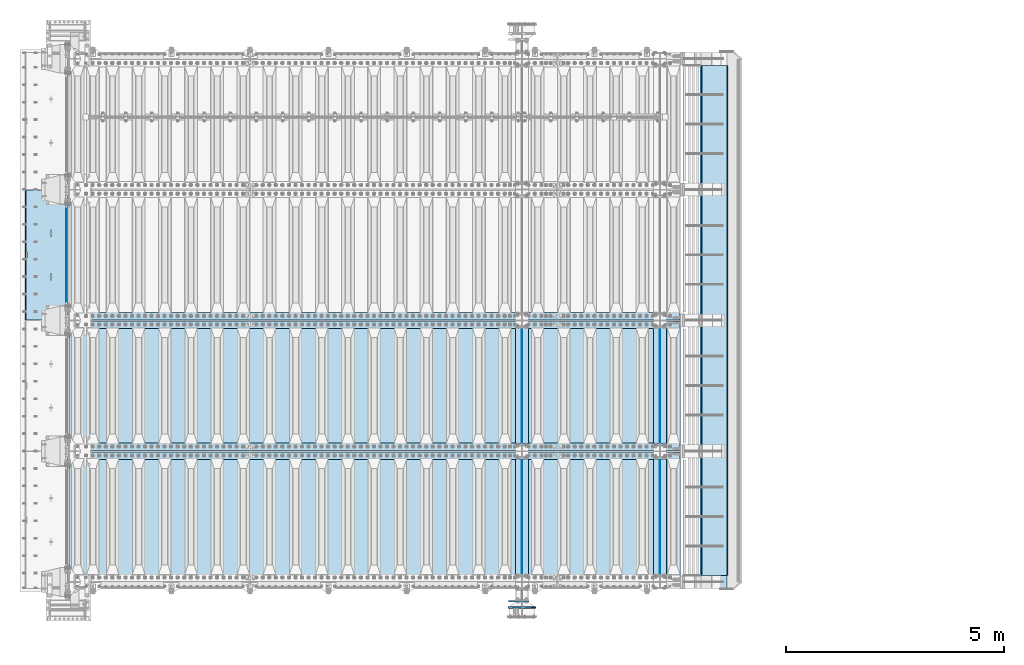
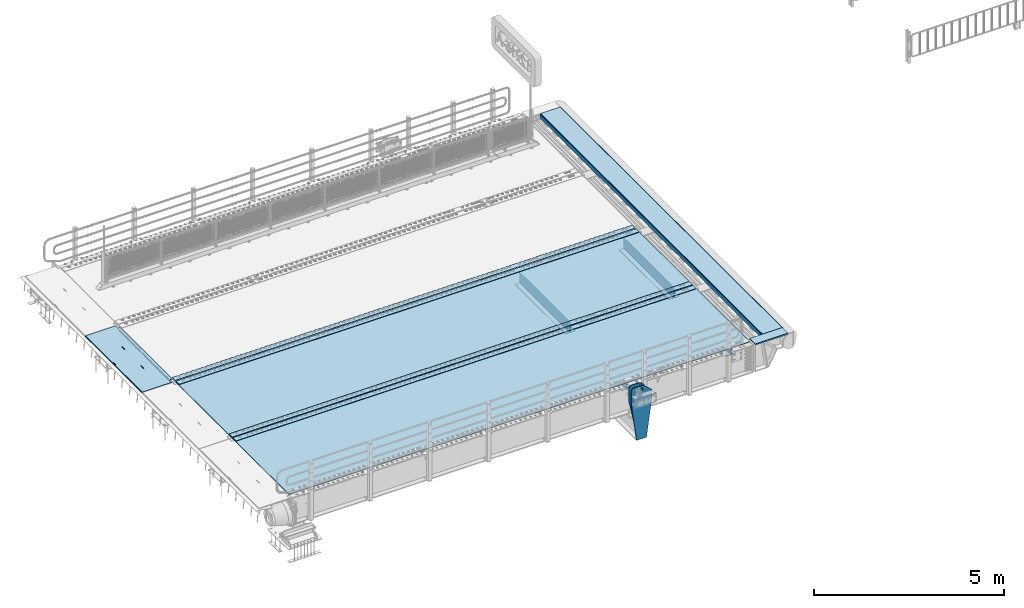
# One storey, part 187 of 240: 21 plates.
"""IFC2X3 building model written with IfcOpenShell, lengths in millimetres."""

from ifc_helpers import new_model, si_unit, frame, origin_with_axes, place, context, subcontext, project, spatial, faceted_brep, material, type_object, element, save


model = new_model("IFC2X3")

# Units and contexts
model_context = context("Model", 3, precision=1e-05, world=origin_with_axes())
body_context = subcontext(model_context, "Body", "Model", "MODEL_VIEW")
ifc_project = project(units=[si_unit("LENGTHUNIT", "METRE", prefix="MILLI"), si_unit("AREAUNIT", "SQUARE_METRE"), si_unit("VOLUMEUNIT", "CUBIC_METRE"), si_unit("MASSUNIT", "GRAM", prefix="KILO"), si_unit("TIMEUNIT", "SECOND"), si_unit("PLANEANGLEUNIT", "RADIAN"), si_unit("SOLIDANGLEUNIT", "STERADIAN"), si_unit("THERMODYNAMICTEMPERATUREUNIT", "DEGREE_CELSIUS"), si_unit("LUMINOUSINTENSITYUNIT", "LUMEN")], contexts=[model_context])

# Site, building, storey
site_placement = place(None, origin_with_axes())
site = spatial("IfcSite", under=ifc_project, at=site_placement, CompositionType="ELEMENT")
building_placement = place(site_placement, origin_with_axes())
building = spatial("IfcBuilding", under=site, at=building_placement, Name="Standard", CompositionType="ELEMENT")
storey_placement = place(building_placement, origin_with_axes())
storey = spatial("IfcBuildingStorey", under=building, at=storey_placement, Name="Undefined", CompositionType="ELEMENT", Elevation=0.0)

# Plates
ifc_material_1 = material(Name="STEEL/S355N")
plate_type_1 = type_object("IfcPlateType", PredefinedType="NOTDEFINED")
plate_1_placement = place(storey_placement, frame((42392.5, 32845.0000994083, -36.0014545213866), z_axis=(0.0, -0.999999999987744, -4.95099999993769e-06), x_axis=(0.0, 4.9510000093107e-06, -0.999999999987744)))
element("IfcPlate", 1, at=plate_1_placement, inside=storey, type_object=plate_type_1, material=ifc_material_1, context=body_context, shape_type="Brep", body=[
    faceted_brep([(7.105427357601e-15, -7.5, 0.0), (-1.24849464100407e-10, -7.5, 70.0), (-1.24849464100407e-10, 7.5, 70.0), (7.105427357601e-15, 7.5, 0.0), (-14.9899997711175, -7.5, 70.0), (-14.9899997711175, 7.5, 70.0), (-14.9899997711161, -7.5, 219.999999999996), (-14.9899997711161, 7.5, 219.999999999996), (-3.90826926377486e-10, -7.5, 220.0), (-3.90826926377486e-10, 7.5, 220.0), (-6.56825704936637e-10, -7.5, 369.999999999996), (-6.56825704936637e-10, 7.5, 369.999999999996), (-14.9899997711147, -7.5, 370.0), (-14.9899997711147, 7.5, 370.0), (-14.9899997711133, -7.5, 520.0), (-14.9899997711133, 7.5, 520.0), (-9.24622156617261e-10, -7.5, 520.0), (-9.24622156617261e-10, 7.5, 520.0), (-1.1906067243217e-09, -7.5, 670.0), (-1.1906067243217e-09, 7.5, 670.0), (-14.9899997711119, -7.5, 670.0), (-14.9899997711119, 7.5, 670.0), (-14.9899997711105, -7.5, 820.0), (-14.9899997711105, 7.5, 820.0), (-1.45477230262259e-09, -7.5, 819.999999999996), (-1.45477230262259e-09, 7.5, 819.999999999996), (-1.72258296515793e-09, -7.5, 970.0), (-1.72258296515793e-09, 7.5, 970.0), (-14.9899997711091, -7.5, 970.0), (-14.9899997711091, 7.5, 970.0), (-14.9899997711077, -7.5, 1120.0), (-14.9899997711077, 7.5, 1120.0), (-1.988560427435e-09, -7.5, 1120.0), (-1.988560427435e-09, 7.5, 1120.0), (-2.2545521005668e-09, -7.5, 1270.0), (-2.2545521005668e-09, 7.5, 1270.0), (-14.9899997711063, -7.5, 1270.0), (-14.9899997711063, 7.5, 1270.0), (-14.9899997711048, -7.5, 1420.0), (-14.9899997711048, 7.5, 1420.0), (-2.52235565767478e-09, -7.5, 1420.0), (-2.52235565767478e-09, 7.5, 1420.0), (-2.78834733080657e-09, -7.5, 1570.0), (-2.78834733080657e-09, 7.5, 1570.0), (-14.9899997711034, -7.5, 1570.0), (-14.9899997711034, 7.5, 1570.0), (-14.989999771102, -7.5, 1720.0), (-14.989999771102, 7.5, 1720.0), (-3.05432479308365e-09, -7.5, 1720.0), (-3.05432479308365e-09, 7.5, 1720.0), (-3.32212835019163e-09, -7.5, 1870.0), (-3.32212835019163e-09, 7.5, 1870.0), (-14.9899997711006, -7.5, 1870.0), (-14.9899997711006, 7.5, 1870.0), (-14.9899997710992, -7.5, 2020.0), (-14.9899997710992, 7.5, 2020.0), (-3.58812002332343e-09, -7.5, 2020.0), (-3.58812002332343e-09, 7.5, 2020.0), (-3.85410459102786e-09, -7.5, 2170.0), (-3.85410459102786e-09, 7.5, 2170.0), (-14.9899997710978, -7.5, 2170.0), (-14.9899997710978, 7.5, 2170.0), (-14.9899997710964, -7.5, 2320.0), (-14.9899997710964, 7.5, 2320.0), (-4.12190104270849e-09, -7.5, 2320.0), (-4.12190104270849e-09, 7.5, 2320.0), (-4.38789982126764e-09, -7.5, 2470.0), (-4.38789982126764e-09, 7.5, 2470.0), (-14.9999999999768, -7.5, 2470.0), (-14.9999999999768, 7.5, 2470.0), (-14.9899997710936, -7.5, 2620.0), (-14.9899997710936, 7.5, 2620.0), (-4.65387728354472e-09, -7.5, 2620.0), (-4.65387728354472e-09, 7.5, 2620.0), (-4.77872674764512e-09, -7.5, 2690.0), (-4.77872674764512e-09, 7.5, 2690.0), (25.0100002289071, -7.5, 2690.0), (25.0100002289071, 7.5, 2690.0), (25.0, -7.5, 0.0), (25.0, 7.5, 0.0)], [[[0, 1, 2, 3]], [[1, 4, 5, 2]], [[4, 6, 7, 5]], [[6, 8, 9, 7]], [[8, 10, 11, 9]], [[10, 12, 13, 11]], [[12, 14, 15, 13]], [[14, 16, 17, 15]], [[16, 18, 19, 17]], [[18, 20, 21, 19]], [[20, 22, 23, 21]], [[22, 24, 25, 23]], [[24, 26, 27, 25]], [[26, 28, 29, 27]], [[28, 30, 31, 29]], [[30, 32, 33, 31]], [[32, 34, 35, 33]], [[34, 36, 37, 35]], [[36, 38, 39, 37]], [[38, 40, 41, 39]], [[40, 42, 43, 41]], [[42, 44, 45, 43]], [[44, 46, 47, 45]], [[46, 48, 49, 47]], [[48, 50, 51, 49]], [[50, 52, 53, 51]], [[52, 54, 55, 53]], [[54, 56, 57, 55]], [[56, 58, 59, 57]], [[58, 60, 61, 59]], [[60, 62, 63, 61]], [[62, 64, 65, 63]], [[64, 66, 67, 65]], [[66, 68, 69, 67]], [[68, 70, 71, 69]], [[70, 72, 73, 71]], [[72, 74, 75, 73]], [[74, 76, 77, 75]], [[76, 78, 79, 77]], [[78, 0, 3, 79]], [[5, 7, 9, 11, 13, 15, 17, 19, 21, 23, 25, 27, 29, 31, 33, 35, 37, 39, 41, 43, 45, 47, 49, 51, 53, 55, 57, 59, 61, 63, 65, 67, 69, 71, 73, 75, 77, 79, 3, 2]], [[78, 76, 74, 72, 70, 68, 66, 64, 62, 60, 58, 56, 54, 52, 50, 48, 46, 44, 42, 40, 38, 36, 34, 32, 30, 28, 26, 24, 22, 20, 18, 16, 14, 12, 10, 8, 6, 4, 1, 0]]]),
])
plate_type_2 = type_object("IfcPlateType", PredefinedType="NOTDEFINED")
plate_2_placement = place(storey_placement, frame((42444.9962456697, 32994.9999261728, -1.00001208605641), z_axis=(0.0, -0.999999999987744, -4.95099999993769e-06), x_axis=(-0.999999999879068, -1.00000022173607e-09, -1.55519999981193e-05)))
element("IfcPlate", 2, at=plate_2_placement, inside=storey, type_object=plate_type_2, material=ifc_material_1, context=body_context, shape_type="Brep", body=[
    faceted_brep([(-0.000111589528387412, -5.71507111812863e-05, 2865.00000504127), (15.000238879169, 15.0, 2865.00008049106), (15.0000104223145, 15.0, 125.000079348185), (-0.000225737421715166, 5.71560163176166e-05, 125.00000363258), (999.996459960938, 5.0, 0.0), (984.996459960938, 15.0, 3.63797880709171e-12), (984.996459730719, 15.0, 2990.0), (999.996459730726, 5.0, 2990.0), (999.996459730726, -5.0, 2990.0), (984.99645973053, -15.0, 2990.0), (984.996459961367, -15.0, 0.0), (999.996459960938, -4.99999999999849, 0.0), (959.999522276543, -15.0000000031848, 1560.00000000859), (959.999522276543, 15.0, 1560.00000000858), (960.488957113346, 15.0, 1563.09016995233), (960.488957113346, -15.0000000031888, 1563.09016995233), (961.909352332339, 15.0, 1565.87785253151), (961.909352332339, -15.0000000032008, 1565.87785253151), (964.121669752989, 15.0, 1568.09016995233), (964.121669752989, -15.0000000032196, 1568.09016995233), (966.909352332048, 15.0, 1569.51056517153), (966.909352332055, -15.0000000032433, 1569.51056517153), (969.99952227575, 15.0, 1570.00000000859), (969.999522275757, -15.0000000032698, 1570.00000000859), (973.089692219539, 15.0, 1569.51056517153), (973.089692219546, -15.0000000032963, 1569.51056517154), (975.877374798838, 15.0, 1568.09016995233), (975.877374798831, -15.0000000033202, 1568.09016995233), (978.08969221983, 15.0, 1565.87785253151), (978.089692219837, -15.0000000033393, 1565.87785253151), (979.510087439237, 15.0, 1563.09016995232), (979.510087439237, -15.0000000033517, 1563.09016995232), (979.999522276528, 15.0, 1560.00000000857), (979.999522276528, -15.0000000033561, 1560.00000000857), (979.999522286394, 15.0, 1430.00000000857), (979.999522286394, -15.0000000033654, 1430.00000000857), (979.510087449584, 15.0, 1426.90983006483), (979.510087449584, -15.0000000033615, 1426.90983006483), (978.089692230598, 15.0, 1424.12214748565), (978.089692230591, -15.0000000033495, 1424.12214748566), (975.877374809941, 15.0, 1421.90983006484), (975.877374809941, -15.0000000033307, 1421.90983006483), (973.089692230875, 15.0, 1420.48943484563), (973.089692230875, -15.0000000033069, 1420.48943484563), (969.999522287326, 15.0, 1420.00000000858), (969.999522287326, -15.0000000032805, 1420.00000000859), (966.909352343537, 15.0, 1420.48943484563), (966.909352343544, -15.000000003254, 1420.48943484563), (964.121669764252, 15.0, 1421.90983006484), (964.121669764259, -15.00000000323, 1421.90983006484), (961.909352343268, 15.0, 1424.12214748566), (961.909352343268, -15.0000000032109, 1424.12214748566), (960.488957123845, 15.0, 1426.90983006483), (960.488957123845, -15.0000000031986, 1426.90983006483), (959.999522286562, 15.0, 1430.00000000858), (959.999522286562, -15.0000000031942, 1430.00000000859), (-0.000461898962385021, -14.9999999925605, 124.999928197292), (-0.000462055562820751, -14.9999999889596, 2864.99992960657), (75.0002624102563, 15.0, 125.00008047176), (74.999789880254, -15.0, 124.999929601763), (74.9997820615827, -15.0, 0.0), (75.0002485915757, 15.0, 0.0), (75.0005015106071, 15.0, 2990.0), (75.0000289806048, -15.0, 2990.0), (75.0004911355936, 15.0, 2865.00008054909), (75.0000186055913, -14.999999997918, 2864.99992967908), (395.488957121612, -15.0, 1926.90983006551), (395.488957121612, 15.0, 1926.90983006551), (394.999522284321, 15.0, 1930.00000000926), (394.999522284321, -15.0, 1930.00000000926), (396.909352341027, -15.0, 1924.12214748633), (396.909352341027, 15.0, 1924.12214748633), (399.121669762026, -15.0, 1921.90983006551), (399.121669762026, 15.0, 1921.90983006551), (401.90935234131, -15.0, 1920.48943484631), (401.909352341303, 15.0, 1920.48943484631), (404.999522285092, -15.0, 1920.00000000926), (404.999522285092, 15.0, 1920.00000000926), (408.08969222867, -15.0, 1920.48943484631), (408.089692228663, 15.0, 1920.48943484631), (410.877374807729, -15.0, 1921.90983006551), (410.877374807729, 15.0, 1921.90983006551), (413.089692228386, -15.0, 1924.12214748633), (413.089692228379, 15.0, 1924.12214748633), (414.510087447372, -15.0, 1926.9098300655), (414.510087447372, 15.0, 1926.9098300655), (414.99952228419, -15.0, 1930.00000000925), (414.999522284183, 15.0, 1930.00000000925), (414.999522274295, -15.0, 2060.00000000925), (414.999522274295, 15.0, 2060.00000000925), (414.510087437004, -15.0, 2063.090169953), (414.510087437004, 15.0, 2063.090169953), (413.089692217596, -15.0, 2065.87785253218), (413.089692217596, 15.0, 2065.87785253218), (410.87737479659, -15.0, 2068.09016995301), (410.87737479659, 15.0, 2068.09016995301), (408.08969221732, -15.0, 2069.51056517221), (408.08969221732, 15.0, 2069.51056517221), (404.999522273523, -15.0, 2070.00000000926), (404.999522273523, 15.0, 2070.00000000926), (401.909352329829, -15.0, 2069.51056517222), (401.909352329822, 15.0, 2069.51056517221), (399.121669750748, -15.0, 2068.09016995301), (399.121669750755, 15.0, 2068.09016995301), (396.909352330098, -15.0, 2065.87785253218), (396.909352330105, 15.0, 2065.87785253218), (395.488957111113, -15.0, 2063.090169953), (395.488957111113, 15.0, 2063.09016995301), (394.999522274302, -15.0, 2060.00000000926), (394.999522274302, 15.0, 2060.00000000926), (395.488957188121, -15.0, 1063.09016995165), (396.909352407107, -15.0, 1065.87785253083), (399.121669827764, -15.0, 1068.09016995166), (401.90935240683, -15.0, 1069.51056517086), (404.999522350525, -15.0, 1070.00000000791), (408.089692294321, -15.0, 1069.51056517086), (410.877374873606, -15.0, 1068.09016995166), (413.089692294605, -15.0, 1065.87785253083), (414.510087514012, -15.0, 1063.09016995165), (414.999522351303, -15.0, 1060.0000000079), (414.999522361191, -15.0, 930.000000007902), (414.510087524373, -15.0, 926.909830064153), (413.089692305402, -15.0, 924.122147484984), (410.877374884738, -15.0, 921.90983006416), (408.089692305679, -15.0, 920.489434844956), (404.999522362101, -15.0, 920.000000007909), (401.909352418326, -15.0, 920.489434844963), (399.121669839034, -15.0, 921.90983006416), (396.909352418043, -15.0, 924.122147484984), (395.488957198613, -15.0, 926.909830064156), (394.99952236133, -15.0, 930.000000007909), (394.999522351311, -15.0, 1060.00000000791), (396.909352418043, 15.0, 924.122147484984), (395.488957198613, 15.0, 926.909830064156), (399.121669839027, 15.0, 921.90983006416), (401.909352418319, 15.0, 920.48943484496), (404.999522362101, 15.0, 920.000000007905), (408.089692305672, 15.0, 920.489434844956), (410.877374884738, 15.0, 921.90983006416), (413.089692305395, 15.0, 924.122147484981), (414.510087524373, 15.0, 926.909830064149), (414.999522361184, 15.0, 930.000000007902), (414.999522351303, 15.0, 1060.0000000079), (414.51008751402, 15.0, 1063.09016995165), (413.089692294598, 15.0, 1065.87785253083), (410.877374873606, 15.0, 1068.09016995165), (408.089692294314, 15.0, 1069.51056517086), (404.999522350532, 15.0, 1070.00000000791), (401.90935240683, 15.0, 1069.51056517086), (399.121669827764, 15.0, 1068.09016995166), (396.909352407107, 15.0, 1065.87785253083), (395.488957188121, 15.0, 1063.09016995165), (394.999522351311, 15.0, 1060.00000000791), (394.99952236133, 15.0, 930.000000007909)], [[[0, 1, 2, 3]], [[4, 5, 6, 7]], [[8, 9, 10, 11]], [[12, 13, 14, 15]], [[15, 14, 16, 17]], [[17, 16, 18, 19]], [[19, 18, 20, 21]], [[21, 20, 22, 23]], [[23, 22, 24, 25]], [[25, 24, 26, 27]], [[27, 26, 28, 29]], [[29, 28, 30, 31]], [[31, 30, 32, 33]], [[33, 32, 34, 35]], [[35, 34, 36, 37]], [[37, 36, 38, 39]], [[39, 38, 40, 41]], [[41, 40, 42, 43]], [[43, 42, 44, 45]], [[45, 44, 46, 47]], [[47, 46, 48, 49]], [[49, 48, 50, 51]], [[51, 50, 52, 53]], [[53, 52, 54, 55]], [[55, 54, 13, 12]], [[56, 57, 0, 3]], [[58, 59, 56, 3, 2]], [[60, 59, 58, 61]], [[11, 10, 60, 61, 5, 4]], [[8, 11, 4, 7]], [[62, 63, 9, 8, 7, 6]], [[63, 62, 64, 65]], [[57, 65, 64, 1, 0]], [[66, 67, 68, 69]], [[70, 71, 67, 66]], [[72, 73, 71, 70]], [[74, 75, 73, 72]], [[76, 77, 75, 74]], [[78, 79, 77, 76]], [[80, 81, 79, 78]], [[82, 83, 81, 80]], [[84, 85, 83, 82]], [[86, 87, 85, 84]], [[88, 89, 87, 86]], [[90, 91, 89, 88]], [[92, 93, 91, 90]], [[94, 95, 93, 92]], [[96, 97, 95, 94]], [[98, 99, 97, 96]], [[100, 101, 99, 98]], [[102, 103, 101, 100]], [[104, 105, 103, 102]], [[106, 107, 105, 104]], [[108, 109, 107, 106]], [[69, 68, 109, 108]], [[63, 65, 57, 56, 59, 60, 10, 9], [15, 17, 19, 21, 23, 25, 27, 29, 31, 33, 35, 37, 39, 41, 43, 45, 47, 49, 51, 53, 55, 12], [110, 111, 112, 113, 114, 115, 116, 117, 118, 119, 120, 121, 122, 123, 124, 125, 126, 127, 128, 129, 130, 131], [106, 104, 102, 100, 98, 96, 94, 92, 90, 88, 86, 84, 82, 80, 78, 76, 74, 72, 70, 66, 69, 108]], [[128, 132, 133, 129]], [[127, 134, 132, 128]], [[126, 135, 134, 127]], [[125, 136, 135, 126]], [[124, 137, 136, 125]], [[123, 138, 137, 124]], [[122, 139, 138, 123]], [[121, 140, 139, 122]], [[120, 141, 140, 121]], [[119, 142, 141, 120]], [[118, 143, 142, 119]], [[117, 144, 143, 118]], [[116, 145, 144, 117]], [[115, 146, 145, 116]], [[114, 147, 146, 115]], [[113, 148, 147, 114]], [[112, 149, 148, 113]], [[111, 150, 149, 112]], [[110, 151, 150, 111]], [[131, 152, 151, 110]], [[130, 153, 152, 131]], [[129, 133, 153, 130]], [[64, 62, 6, 5, 61, 58, 2, 1], [50, 48, 46, 44, 42, 40, 38, 36, 34, 32, 30, 28, 26, 24, 22, 20, 18, 16, 14, 13, 54, 52], [132, 134, 135, 136, 137, 138, 139, 140, 141, 142, 143, 144, 145, 146, 147, 148, 149, 150, 151, 152, 153, 133], [71, 73, 75, 77, 79, 81, 83, 85, 87, 89, 91, 93, 95, 97, 99, 101, 103, 105, 107, 109, 68, 67]]]),
])
plate_type_3 = type_object("IfcPlateType", PredefinedType="NOTDEFINED")
for number, where, z_axis, x_axis in (
    (3, (56005.0, 29825.0, 0.0), (0.0, 0.0, -1.0), (0.0, -1.0, 0.0)),
    (4, (56005.0, 26825.0, 0.0), (0.0, 0.0, -1.0), (0.0, -1.0, 0.0)),
    (5, (52840.0, 29825.0, 0.0), (0.0, 0.0, -1.0), (0.0, -1.0, 0.0)),
    (6, (52840.0, 26825.0, 0.0), (0.0, 0.0, -1.0), (0.0, -1.0, 0.0)),
):
    element("IfcPlate", number, at=place(storey_placement, frame(where, z_axis=z_axis, x_axis=x_axis)), inside=storey, type_object=plate_type_3, material=ifc_material_1, context=body_context, shape_type="Brep", body=[
        faceted_brep([(0.0, -5.0, 0.0), (0.0, -5.0, 336.0), (0.0, 5.0, 336.0), (0.0, 5.0, 0.0), (2650.0, -5.0, 336.0), (2650.0, 5.0, 336.0), (2650.0, -5.0, 0.0), (2650.0, 5.0, 0.0)], [[[0, 1, 2, 3]], [[1, 4, 5, 2]], [[4, 6, 7, 5]], [[6, 0, 3, 7]], [[5, 7, 3, 2]], [[6, 4, 1, 0]]]),
    ])
plate_type_4 = type_object("IfcPlateType", PredefinedType="NOTDEFINED")
for number, where, z_axis, x_axis in (
    (7, (55855.0, 27175.0, -343.0), (0.0, 1.0, 0.0), (1.0, 0.0, 0.0)),
    (8, (55855.0, 24175.0, -343.0), (0.0, 1.0, 0.0), (1.0, 0.0, 0.0)),
    (9, (52690.0, 27175.0, -343.0), (0.0, 1.0, 0.0), (1.0, 0.0, 0.0)),
    (10, (52690.0, 24175.0, -343.0), (0.0, 1.0, 0.0), (1.0, 0.0, 0.0)),
):
    element("IfcPlate", number, at=place(storey_placement, frame(where, z_axis=z_axis, x_axis=x_axis)), inside=storey, type_object=plate_type_4, material=ifc_material_1, context=body_context, shape_type="Brep", body=[
        faceted_brep([(0.0, -7.0, 0.0), (0.0, -7.0, 2650.0), (0.0, 7.0, 2650.0), (0.0, 7.0, 0.0), (300.0, -7.0, 2650.0), (300.0, 7.0, 2650.0), (300.0, -7.0, 0.0), (300.0, 7.0, 0.0)], [[[0, 1, 2, 3]], [[1, 4, 5, 2]], [[4, 6, 7, 5]], [[6, 0, 3, 7]], [[5, 7, 3, 2]], [[6, 4, 1, 0]]]),
    ])
plate_type_5 = type_object("IfcPlateType", PredefinedType="NOTDEFINED")
plate_3_placement = place(storey_placement, frame((56556.9988298906, 24150.0, -9.99999999985041), z_axis=(1.0, 0.0, 0.0), x_axis=(0.0, -1.0, 0.0)))
element("IfcPlate", 11, at=plate_3_placement, inside=storey, type_object=plate_type_5, material=ifc_material_1, context=body_context, shape_type="Brep", body=[
    faceted_brep([(300.0, 7.0, 986.0), (300.0, 20.0, 956.0), (-3.63797880709171e-11, 20.0, 956.0), (-3.63797880709171e-11, 7.0, 986.0), (0.0, 20.0, 0.0), (0.0, -20.0, 0.0), (-3.63797880709171e-11, -20.0, 986.0), (300.0, -20.0, 986.0), (300.0, -20.0, -1.81898940354586e-12), (300.0, 20.0, -1.81898940354586e-12)], [[[0, 1, 2, 3]], [[4, 5, 6, 3, 2]], [[6, 7, 0, 3]], [[7, 8, 9, 1, 0]], [[8, 5, 4, 9]], [[9, 4, 2, 1]], [[8, 7, 6, 5]]]),
])
ifc_material_2 = material(Name="STEEL/S235JR")
plate_type_6 = type_object("IfcPlateType", PredefinedType="NOTDEFINED")
for number, where, z_axis, x_axis in (
    (12, (56467.0, 30015.0, 20.0), (-1.0, 0.0, 0.0), (0.0, 1.0, 0.0)),
    (13, (56467.0, 29815.0, 20.0), (-1.0, 0.0, 0.0), (0.0, 1.0, 0.0)),
    (14, (56467.0, 27015.0, 20.0), (-1.0, 0.0, 0.0), (0.0, 1.0, 0.0)),
    (15, (56467.0, 26815.0, 20.0), (-1.0, 0.0, 0.0), (0.0, 1.0, 0.0)),
):
    element("IfcPlate", number, at=place(storey_placement, frame(where, z_axis=z_axis, x_axis=x_axis)), inside=storey, type_object=plate_type_6, material=ifc_material_2, context=body_context, shape_type="Brep", body=[
        faceted_brep([(0.0, -6.0, 0.0), (0.0, -6.0, 13997.0), (0.0, 6.0, 13997.0), (0.0, 6.0, 0.0), (170.0, -6.0, 13997.0), (170.0, 6.0, 13997.0), (170.0, -6.0, 0.0), (170.0, 6.0, 0.0)], [[[0, 1, 2, 3]], [[1, 4, 5, 2]], [[4, 6, 7, 5]], [[6, 0, 3, 7]], [[5, 7, 3, 2]], [[6, 4, 1, 0]]]),
    ])
plate_type_7 = type_object("IfcPlateType", PredefinedType="NOTDEFINED")
for number, where, z_axis, x_axis in (
    (16, (42460.0, 29995.0, 7.0), (1.0, 0.0, 0.0), (0.0, -1.0, 0.0)),
    (17, (42460.0, 26995.0, 7.0), (1.0, 0.0, 0.0), (0.0, -1.0, 0.0)),
):
    element("IfcPlate", number, at=place(storey_placement, frame(where, z_axis=z_axis, x_axis=x_axis)), inside=storey, type_object=plate_type_7, material=ifc_material_1, context=body_context, shape_type="Brep", body=[
        faceted_brep([(0.0, -7.0, 0.0), (-2.96859070658684e-09, -7.0, 14017.0), (-2.96859070658684e-09, 7.0, 14017.0), (0.0, 7.0, 0.0), (2990.0, -7.0, 14017.0), (2990.0, 7.0, 14017.0), (2990.0, -7.0, 0.0), (2990.0, 7.0, 0.0)], [[[0, 1, 2, 3]], [[1, 4, 5, 2]], [[4, 6, 7, 5]], [[6, 0, 3, 7]], [[5, 7, 3, 2]], [[6, 4, 1, 0]]]),
    ])
plate_type_8 = type_object("IfcPlateType", PredefinedType="NOTDEFINED")
plate_4_placement = place(storey_placement, frame((53000.0000000139, 23560.0000000344, -945.000018228782), z_axis=(-0.901283188008789, 0.0, 0.433230441004224), x_axis=(-0.433230441004219, 0.0, -0.901283188008791)))
element("IfcPlate", 18, at=plate_4_placement, inside=storey, type_object=plate_type_8, material=ifc_material_1, context=body_context, shape_type="Brep", body=[
    faceted_brep([(22.0942403398949, -15.0000000000073, 175.225838688071), (22.0942403398949, 15.0, 175.225838688071), (270.848389278413, 15.0, 55.6542422352941), (270.848389278413, -15.0, 55.6542422352941), (15.5957837248316, -15.0000000000073, 161.706590867936), (15.5957837248316, 15.0, 161.706590867936), (264.34993529279, -15.0, 42.1349931512304), (264.34993529279, 15.0, 42.1349931512304), (244.096420288082, -15.0, 2.25554686039686e-10), (244.096420288082, 15.0, 2.25554686039686e-10), (0.0, -15.0, 0.0), (0.0, 15.0, 0.0), (-976.801818847667, -15.0, 469.530853271484), (-976.801818847667, 15.0, 469.530853271484), (-1005.61098604243, -15.0, 584.572481266783), (-1005.61098604243, 15.0, 584.57248126679), (-1008.62084772103, -15.0, 603.379189822277), (-1008.62084772103, 15.0, 603.379189822277), (-1008.34151554686, -14.9999999999964, 622.423179098514), (-1008.34151554686, 15.0000000000036, 622.423179098521), (-1004.78136374959, -14.9999999999964, 641.133520442199), (-1004.78136374959, 15.0000000000036, 641.133520442199), (-998.047107283008, -15.0, 658.949268252029), (-998.047107283008, 15.0, 658.949268252029), (-903.393044122804, -15.0, 855.865689234553), (-903.393044122804, 15.0, 855.865689234553), (-891.965944990749, -15.0, 873.346279725993), (-891.965944990749, 15.0, 873.346279725993), (-876.403904176859, -15.0, 887.273681644823), (-876.403904176859, 15.0, 887.273681644823), (-857.767449567884, -15.0, 896.698765098517), (-857.767449567884, 15.0, 896.698765098517), (-837.326625373305, -15.0, 900.97922590877), (-837.326625373305, 15.0, 900.97922590877), (-816.474440668644, -15.0, 899.823357601352), (-816.474440668644, 15.0, 899.823357601352), (-796.631938081966, -15.0, 893.3099307304), (-796.631938081966, 15.0, 893.3099307304), (-427.10580444337, -14.9999999999964, 715.685363769524), (-427.105804443374, 15.0000000000036, 715.685363769531), (138.633743286129, -15.0, 288.410614013665), (138.633743286129, 15.0, 288.410614013665), (291.101898193352, -15.0, 97.7892227172706), (291.101898193352, 15.0, 97.7892227172706), (-886.32402569419, -15.0000000000146, 572.182288694879), (-886.32402569419, 14.9999999999854, 572.182288694879), (-901.776420283964, 14.9999999999854, 569.989346058661), (-901.776420283964, -15.0000000000146, 569.989346058661), (-872.887077419415, -15.0000000000146, 580.121678912328), (-872.887077419415, 14.9999999999854, 580.121678912328), (-863.511229028238, -15.0000000000146, 592.598816521153), (-863.511229028238, 14.9999999999854, 592.598816521153), (-859.623868445931, -15.0000000000146, 607.714170425934), (-859.623868445931, 14.9999999999854, 607.714170425934), (-861.81681108215, -15.0000000000146, 623.166565015716), (-861.81681108215, 14.9999999999854, 623.166565015716), (-869.756201299595, -15.0000000000146, 636.603513290487), (-869.756201299595, 14.9999999999854, 636.603513290487), (-882.23333890842, -15.0000000000146, 645.979361681668), (-882.23333890842, 14.9999999999854, 645.979361681668), (-897.348692813208, -15.0000000000146, 649.866722263971), (-897.348692813208, 14.9999999999854, 649.866722263971), (-912.801087402986, -15.0000000000146, 647.673779627759), (-912.801087402986, 14.9999999999854, 647.673779627759), (-926.238035677761, -15.0000000000146, 639.734389410303), (-926.238035677761, 14.9999999999854, 639.734389410303), (-935.613884068938, -15.0000000000146, 627.257251801486), (-935.613884068938, 14.9999999999854, 627.257251801486), (-939.501244651245, -15.0000000000146, 612.141897896698), (-939.501244651245, 14.9999999999854, 612.141897896698), (-937.308302015026, -15.0000000000146, 596.689503306923), (-937.308302015026, 14.9999999999854, 596.689503306923), (-929.368911797577, -15.0000000000146, 583.252555032144), (-929.368911797577, 14.9999999999854, 583.252555032144), (-916.891774188756, -15.0000000000146, 573.876706640964), (-916.891774188756, 14.9999999999854, 573.876706640964), (-844.133640483451, 15.0, 583.284362042752), (-843.858297567211, 15.0, 588.251621173127), (-847.175983338977, 15.0, 591.958700631338), (-852.143242469345, 15.0, 592.234043547585), (-855.850321927563, 15.0, 588.916357775808), (-856.125664843803, 15.0, 583.949098645448), (-852.807979072033, 15.0, 580.242019187222), (-847.840719941669, 15.0, 579.966676270989), (-847.840719941669, -15.0, 579.966676270989), (-852.807979072033, -15.0, 580.242019187222), (-844.133640483451, -15.0, 583.284362042752), (-843.858297567211, -15.0, 588.251621173127), (-847.175983338977, -15.0, 591.958700631338), (-852.143242469345, -15.0, 592.234043547585), (-855.850321927563, -15.0, 588.916357775808), (-856.125664843803, -15.0, 583.949098645448)], [[[0, 1, 2, 3]], [[4, 5, 1, 0]], [[6, 7, 5, 4]], [[8, 9, 7, 6]], [[8, 10, 11, 9]], [[10, 12, 13, 11]], [[12, 14, 15, 13]], [[14, 16, 17, 15]], [[16, 18, 19, 17]], [[18, 20, 21, 19]], [[20, 22, 23, 21]], [[22, 24, 25, 23]], [[24, 26, 27, 25]], [[26, 28, 29, 27]], [[28, 30, 31, 29]], [[30, 32, 33, 31]], [[32, 34, 35, 33]], [[34, 36, 37, 35]], [[36, 38, 39, 37]], [[38, 40, 41, 39]], [[40, 42, 43, 41]], [[43, 42, 3, 2]], [[44, 45, 46, 47]], [[48, 49, 45, 44]], [[50, 51, 49, 48]], [[52, 53, 51, 50]], [[54, 55, 53, 52]], [[56, 57, 55, 54]], [[58, 59, 57, 56]], [[60, 61, 59, 58]], [[62, 63, 61, 60]], [[64, 65, 63, 62]], [[66, 67, 65, 64]], [[68, 69, 67, 66]], [[70, 71, 69, 68]], [[72, 73, 71, 70]], [[74, 75, 73, 72]], [[47, 46, 75, 74]], [[9, 11, 13, 15, 17, 19, 21, 23, 25, 27, 29, 31, 33, 35, 37, 39, 41, 43, 2, 1, 5, 7], [76, 77, 78, 79, 80, 81, 82, 83], [45, 49, 51, 53, 55, 57, 59, 61, 63, 65, 67, 69, 71, 73, 75, 46]], [[84, 83, 82, 85]], [[86, 76, 83, 84]], [[87, 77, 76, 86]], [[88, 78, 77, 87]], [[89, 79, 78, 88]], [[90, 80, 79, 89]], [[91, 81, 80, 90]], [[85, 82, 81, 91]], [[3, 42, 40, 38, 36, 34, 32, 30, 28, 26, 24, 22, 20, 18, 16, 14, 12, 10, 8, 6, 4, 0], [90, 89, 88, 87, 86, 84, 85, 91], [70, 68, 66, 64, 62, 60, 58, 56, 54, 52, 50, 48, 44, 47, 74, 72]]]),
])
plate_type_9 = type_object("IfcPlateType", PredefinedType="NOTDEFINED")
plate_5_placement = place(storey_placement, frame((52990.0, 23420.0000000345, -1470.00001822227), z_axis=(0.0, 0.0, 1.0), x_axis=(-1.0, 0.0, 0.0)))
element("IfcPlate", 19, at=plate_5_placement, inside=storey, type_object=plate_type_9, material=ifc_material_1, context=body_context, shape_type="Brep", body=[
    faceted_brep([(145.403805922288, -15.0000000000036, 1549.59619407771), (145.403805922288, 14.9999999999964, 1549.59619407771), (150.0, 14.9999999999964, 1551.5), (150.0, -15.0000000000036, 1551.5), (154.596194077712, 14.9999999999964, 1549.59619407771), (154.596194077712, -15.0000000000036, 1549.59619407771), (156.5, 14.9999999999964, 1545.0), (156.5, -15.0000000000036, 1545.0), (154.596194077712, 14.9999999999964, 1540.40380592229), (154.596194077712, -15.0000000000036, 1540.40380592229), (150.0, 14.9999999999964, 1538.5), (150.0, -15.0000000000036, 1538.5), (145.403805922288, 14.9999999999964, 1540.40380592229), (145.403805922288, -15.0000000000036, 1540.40380592229), (143.5, 14.9999999999964, 1545.0), (143.5, -15.0000000000036, 1545.0), (300.0, -15.0, 0.0), (0.0, -15.0, 0.0), (0.0, 15.0, 0.0), (300.0, 15.0, 0.0), (462.5, -15.0, 1210.0), (462.5, 15.0, 1210.0), (462.5, -15.0, 1630.0), (462.5, 15.0, 1630.0), (459.774066103128, -15.0, 1650.7055236082), (459.774066103128, 15.0, 1650.7055236082), (451.782032302755, -15.0, 1670.0), (451.782032302755, 15.0, 1670.0), (439.068542494926, -15.0, 1686.56854249492), (439.068542494926, 15.0, 1686.56854249492), (422.5, -15.0, 1699.28203230276), (422.5, 15.0, 1699.28203230276), (403.205523608201, -15.0, 1707.27406610313), (403.205523608201, 15.0, 1707.27406610313), (382.5, -15.0, 1710.0), (382.5, 15.0, 1710.0), (151.788081037077, -15.0, 1710.0), (151.788081037077, 15.0, 1710.0), (132.694887325029, -15.0, 1708.33028179541), (132.694887325029, 15.0, 1708.33028179541), (114.181334578883, -15.0, 1703.37181734316), (114.181334578883, 15.0, 1703.37181734316), (96.8094667268524, -15.0, 1695.27513824985), (96.8094667268524, 15.0, 1695.27513824985), (81.1066678416755, -15.0, 1684.28604765144), (81.1066678416755, 15.0, 1684.28604765144), (-162.5, -15.0, 1480.0), (-162.5, 15.0, 1480.0), (-162.5, -15.0, 1210.0), (-162.5, 15.0, 1210.0), (121.715728752541, -15.0, 1628.28427124746), (134.692662705398, -15.0, 1636.95518130045), (150.0, -15.0, 1640.0), (165.307337294602, -15.0, 1636.95518130045), (178.284271247459, -15.0, 1628.28427124746), (186.955181300451, -15.0, 1615.3073372946), (190.0, -15.0, 1600.0), (186.955181300451, -15.0, 1584.6926627054), (178.284271247459, -15.0, 1571.71572875254), (165.307337294602, -15.0, 1563.04481869955), (150.0, -15.0, 1560.0), (134.692662705398, -15.0, 1563.04481869955), (121.715728752541, -15.0, 1571.71572875254), (113.044818699549, -15.0, 1584.6926627054), (110.0, -15.0, 1600.0), (113.044818699549, -15.0, 1615.3073372946), (121.715728752541, 15.0, 1571.71572875254), (113.044818699549, 15.0, 1584.6926627054), (134.692662705398, 15.0, 1563.04481869955), (150.0, 15.0, 1560.0), (165.307337294602, 15.0, 1563.04481869955), (178.284271247459, 15.0, 1571.71572875254), (186.955181300451, 15.0, 1584.6926627054), (190.0, 15.0, 1600.0), (186.955181300451, 15.0, 1615.3073372946), (178.284271247459, 15.0, 1628.28427124746), (165.307337294602, 15.0, 1636.95518130045), (150.0, 15.0, 1640.0), (134.692662705398, 15.0, 1636.95518130045), (121.715728752541, 15.0, 1628.28427124746), (113.044818699549, 15.0, 1615.3073372946), (110.0, 15.0, 1600.0)], [[[0, 1, 2, 3]], [[3, 2, 4, 5]], [[5, 4, 6, 7]], [[7, 6, 8, 9]], [[9, 8, 10, 11]], [[11, 10, 12, 13]], [[13, 12, 14, 15]], [[15, 14, 1, 0]], [[16, 17, 18, 19]], [[20, 16, 19, 21]], [[22, 20, 21, 23]], [[24, 22, 23, 25]], [[26, 24, 25, 27]], [[28, 26, 27, 29]], [[30, 28, 29, 31]], [[32, 30, 31, 33]], [[34, 32, 33, 35]], [[36, 34, 35, 37]], [[38, 36, 37, 39]], [[40, 38, 39, 41]], [[42, 40, 41, 43]], [[44, 42, 43, 45]], [[46, 44, 45, 47]], [[48, 46, 47, 49]], [[17, 48, 49, 18]], [[16, 20, 22, 24, 26, 28, 30, 32, 34, 36, 38, 40, 42, 44, 46, 48, 17], [3, 5, 7, 9, 11, 13, 15, 0], [50, 51, 52, 53, 54, 55, 56, 57, 58, 59, 60, 61, 62, 63, 64, 65]], [[62, 66, 67, 63]], [[61, 68, 66, 62]], [[60, 69, 68, 61]], [[59, 70, 69, 60]], [[58, 71, 70, 59]], [[57, 72, 71, 58]], [[56, 73, 72, 57]], [[55, 74, 73, 56]], [[54, 75, 74, 55]], [[53, 76, 75, 54]], [[52, 77, 76, 53]], [[51, 78, 77, 52]], [[50, 79, 78, 51]], [[65, 80, 79, 50]], [[64, 81, 80, 65]], [[63, 67, 81, 64]], [[47, 45, 43, 41, 39, 37, 35, 33, 31, 29, 27, 25, 23, 21, 19, 18, 49], [10, 8, 6, 4, 2, 1, 14, 12], [66, 68, 69, 70, 71, 72, 73, 74, 75, 76, 77, 78, 79, 80, 81, 67]]]),
])
plate_type_10 = type_object("IfcPlateType", PredefinedType="NOTDEFINED")
plate_6_placement = place(storey_placement, frame((56950.5545510642, 35850.0000000016, -155.274111776634), z_axis=(0.0, -1.0, 0.0), x_axis=(-0.0871556999854023, 0.0, 0.996194701832957)))
element("IfcPlate", 20, at=plate_6_placement, inside=storey, type_object=plate_type_10, material=ifc_material_1, context=body_context, shape_type="Brep", body=[
    faceted_brep([(0.0, -10.0, 0.0), (0.0, -10.0000000000073, 11700.0), (0.0, 10.0, 11700.0), (0.0, 10.0, 0.0), (155.0, -10.0, 11700.0), (155.0, 9.99999999999272, 11700.0), (155.0, -10.0, 0.0), (155.0, 9.99999999999272, 0.0)], [[[0, 1, 2, 3]], [[1, 4, 5, 2]], [[4, 6, 7, 5]], [[6, 0, 3, 7]], [[5, 7, 3, 2]], [[6, 4, 1, 0]]]),
])
plate_type_11 = type_object("IfcPlateType", PredefinedType="NOTDEFINED")
plate_7_placement = place(storey_placement, frame((56947.0029680259, 35850.0000000016, 0.00398537333359705), z_axis=(0.999999999980105, 3.15999997831648e-07, -6.29999999987466e-06), x_axis=(0.0, -1.0, 0.0)))
element("IfcPlate", 21, at=plate_7_placement, inside=storey, type_object=plate_type_11, material=ifc_material_1, context=body_context, shape_type="Brep", body=[
    faceted_brep([(11700.0, -10.0, 596.995666503914), (11700.0, -9.280909374354e-13, 616.995666503906), (-3.62124410457909e-08, -9.25814980234918e-13, 616.995788574219), (-3.50410118699074e-08, -10.0, 596.995788574226), (-3.62124410457909e-08, 10.0, 616.995788574219), (0.0, 10.0, 0.0), (0.0, -10.0, 0.0), (11700.0, 10.0, 616.995666503906), (11700.0, -10.0, -3.05662979371846e-08), (11700.0, 10.0, -3.05662979371846e-08)], [[[0, 1, 2, 3]], [[4, 5, 6, 3, 2]], [[7, 4, 2, 1]], [[8, 9, 7, 1, 0]], [[8, 6, 5, 9]], [[7, 9, 5, 4]], [[6, 8, 0, 3]]]),
])

save(model, "model.ifc")
